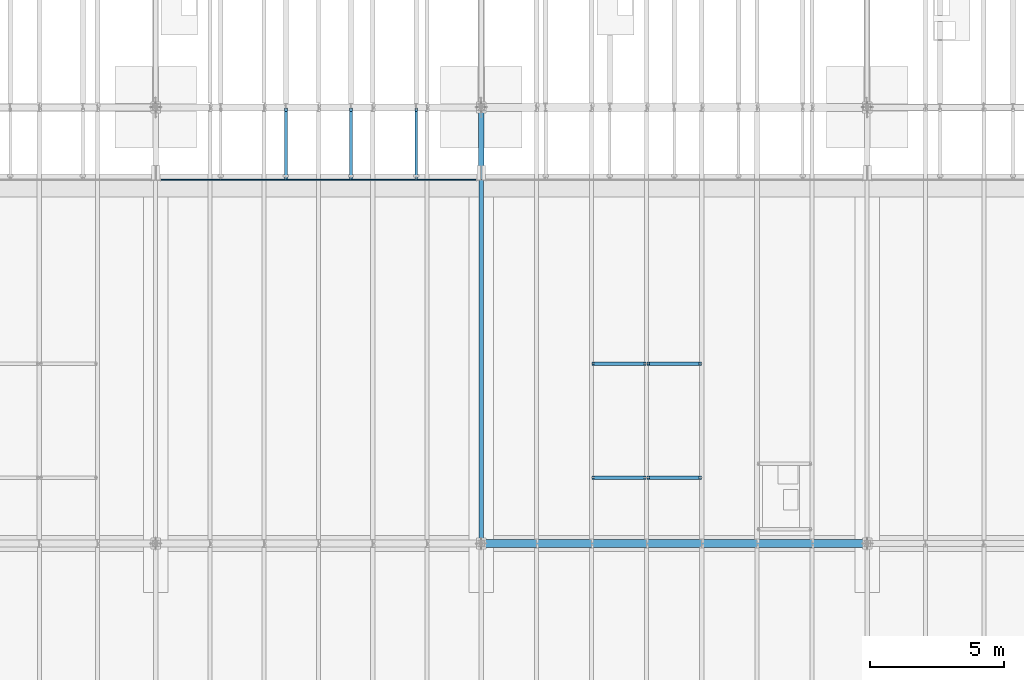
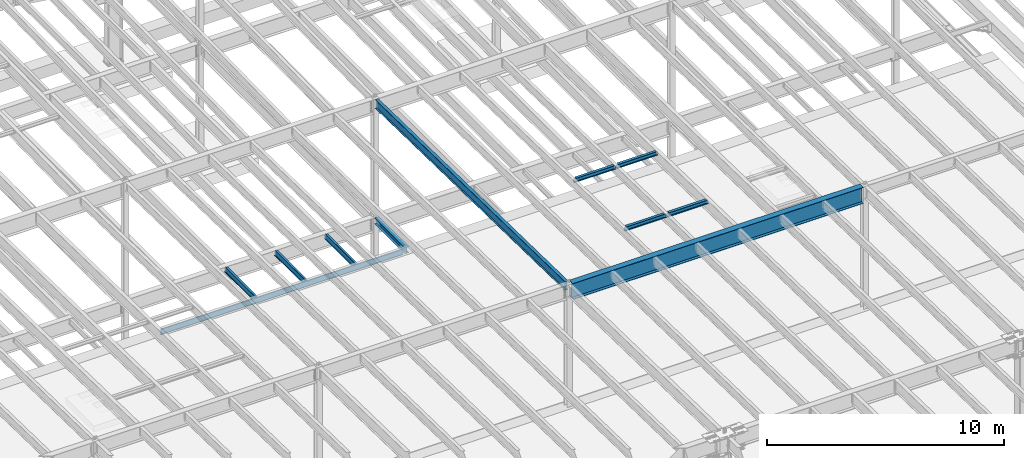
# One storey, part 1101 of 1763: 11 beams, 11 elements without a shape of their own.
"""IFC2X3 building model written with IfcOpenShell, lengths in millimetres."""

import ifcopenshell
import ifcopenshell.guid

model = None  # the IFC model being written
_history = None  # IfcOwnerHistory: only IFC2X3 demands one
_inside = {}  # id of a spatial element -> (the spatial element, [elements in it])
_under = {}  # id of a project, library or spatial element -> (it, [spatial elements below it])
_declared = {}  # id of a project -> (the project, [libraries it declares])
_typed = {}  # id of a type object -> (the type object, [elements of that type])
_made_of = {}  # id of a material, layer set ... -> (it, [elements and type objects made of it])


def new_model(schema):
    """Start an empty IFC model of exactly this schema.

    Asked for "IFC4X3", IfcOpenShell would pick the latest addendum, in which some entities
    have other attributes; the version numbers below select the first issue.
    IFC2X3 requires an IfcOwnerHistory on every rooted entity: one is made here for all.
    """
    global model, _history
    if schema == "IFC4X3":
        model = ifcopenshell.file(schema_version=(4, 3, 0, 0))
    else:
        model = ifcopenshell.file(schema=schema)
    _inside.clear()
    _under.clear()
    _declared.clear()
    _typed.clear()
    _made_of.clear()
    _history = None
    if model.schema == "IFC2X3":
        org = make("IfcOrganization", Name="unknown")
        user = make(
            "IfcPersonAndOrganization",
            ThePerson=make("IfcPerson", FamilyName="unknown"),
            TheOrganization=org,
        )
        app = make(
            "IfcApplication",
            ApplicationDeveloper=org,
            Version="unknown",
            ApplicationFullName="unknown",
            ApplicationIdentifier="unknown",
        )
        _history = make(
            "IfcOwnerHistory",
            OwningUser=user,
            OwningApplication=app,
            ChangeAction="ADDED",
            CreationDate=0,
        )
    return model


def make(cls, **values):
    """One entity of the class cls with the attributes given. An attribute that is None is left unset."""
    return model.create_entity(
        cls, **{name: value for name, value in values.items() if value is not None}
    )


def rooted(cls, **values):
    """An entity with a GlobalId (a new one), such as an element, a storey or a relation."""
    return make(cls, GlobalId=ifcopenshell.guid.new(), OwnerHistory=_history, **values)


def si_unit(unit_type, name, prefix=None):
    """IfcSIUnit, for example si_unit("LENGTHUNIT", "METRE", prefix="MILLI")."""
    return make("IfcSIUnit", UnitType=unit_type, Prefix=prefix, Name=name)


def assignment(units):
    """IfcUnitAssignment: the units of a project."""
    return None if units is None else make("IfcUnitAssignment", Units=units)


def point(xyz):
    """IfcCartesianPoint."""
    return None if xyz is None else make("IfcCartesianPoint", Coordinates=xyz)


def direction(xyz):
    """IfcDirection."""
    return None if xyz is None else make("IfcDirection", DirectionRatios=xyz)


def frame(location, z_axis=None, x_axis=None):
    """IfcAxis2Placement3D, a coordinate frame: its origin and axes. An axis left out is left unset."""
    return make(
        "IfcAxis2Placement3D",
        Location=point(location),
        Axis=direction(z_axis),
        RefDirection=direction(x_axis),
    )


def origin_with_axes():
    """The frame at (0, 0, 0) with the z axis (0, 0, 1) and the x axis (1, 0, 0) written out."""
    return frame((0.0, 0.0, 0.0), z_axis=(0.0, 0.0, 1.0), x_axis=(1.0, 0.0, 0.0))


def place(relative_to, where):
    """IfcLocalPlacement: puts the frame where relative to a parent placement (None: the world)."""
    return make(
        "IfcLocalPlacement", PlacementRelTo=relative_to, RelativePlacement=where
    )


def context(
    kind, dimensions, precision=None, world=None, true_north=None, identifier=None
):
    """IfcGeometricRepresentationContext, for example the 3D "Model" context."""
    return make(
        "IfcGeometricRepresentationContext",
        ContextIdentifier=identifier,
        ContextType=kind,
        CoordinateSpaceDimension=dimensions,
        Precision=precision,
        WorldCoordinateSystem=world,
        TrueNorth=true_north,
    )


def subcontext(parent, identifier, kind, view, scale=None):
    """IfcGeometricRepresentationSubContext, for example "Body" below "Model"."""
    return make(
        "IfcGeometricRepresentationSubContext",
        ContextIdentifier=identifier,
        ContextType=kind,
        ParentContext=parent,
        TargetScale=scale,
        TargetView=view,
    )


def project(units=None, contexts=None):
    """IfcProject with its units and contexts."""
    return rooted(
        "IfcProject",
        Name="project",
        RepresentationContexts=contexts,
        UnitsInContext=assignment(units),
    )


def spatial(cls, under=None, at=None, **own):
    """A site, building, storey or space (cls), placed at a placement, below another one or the project."""
    s = rooted(cls, ObjectPlacement=at, **own)
    if under is not None:
        _under.setdefault(under.id(), (under, []))[1].append(s)
    return s


def faces_of(points, faces, orient=None, outer=None):
    """IfcFace entities. A face is a list of loops; a loop is a list of indices into points, from 0.

    orient and outer hold one flag for each loop. By default every Orientation is true, the
    first loop of a face is its IfcFaceOuterBound and the others are IfcFaceBound.
    """
    made = []
    for i, loops in enumerate(faces):
        bounds = []
        for j, loop in enumerate(loops):
            is_outer = j == 0 if outer is None else outer[i][j]
            bounds.append(
                make(
                    "IfcFaceOuterBound" if is_outer else "IfcFaceBound",
                    Bound=make("IfcPolyLoop", Polygon=[points[k] for k in loop]),
                    Orientation=True if orient is None else orient[i][j],
                )
            )
        made.append(make("IfcFace", Bounds=bounds))
    return made


def faceted_brep(points, faces, orient=None, outer=None, voids=None):
    """IfcFacetedBrep: a solid bounded by flat faces; with voids (closed shells), ...WithVoids."""
    shared = [point(p) for p in points]
    hull = make("IfcClosedShell", CfsFaces=faces_of(shared, faces, orient, outer))
    if voids is None:
        return make("IfcFacetedBrep", Outer=hull)
    return make(
        "IfcFacetedBrepWithVoids",
        Outer=hull,
        Voids=[
            make(cls, CfsFaces=faces_of(shared, fs, o, b)) for cls, fs, o, b in voids
        ],
    )


def shape(context_of_items, identifier, shape_type, items):
    """IfcShapeRepresentation: the items that make up one representation, for example the "Body"."""
    return make(
        "IfcShapeRepresentation",
        ContextOfItems=context_of_items,
        RepresentationIdentifier=identifier,
        RepresentationType=shape_type,
        Items=items,
    )


def material(Name=None, Category=None):
    """IfcMaterial."""
    return make("IfcMaterial", Name=Name, Category=Category)


def made_of(thing, what):
    """Note that an element or type object is made of a material, layer set ...; save() writes the relation."""
    if what is not None:
        _made_of.setdefault(what.id(), (what, []))[1].append(thing)
    return thing


def type_object(cls, material=None, **own):
    """A type object (cls), such as IfcWallType, which elements share."""
    return made_of(rooted(cls, **own), material)


def element(
    cls,
    number,
    at=None,
    inside=None,
    cuts=None,
    type_object=None,
    material=None,
    context=None,
    identifier="Body",
    shape_type=None,
    held_by="IfcProductDefinitionShape",
    body=None,
    shapes=None,
    **own,
):
    """One element of the class cls, such as IfcWall. Its Tag is "e" and its number.

    at: its placement. inside: the storey or other place that contains it. cuts: it is an
    opening in that element (IfcRelVoidsElement). A single representation is given by context,
    identifier, shape_type and body (its items); several are given by shapes. held_by: the class
    of the entity that holds the representations. save() writes the other relations.
    """
    e = rooted(cls, Tag="e%d" % number, ObjectPlacement=at, **own)
    if body is not None:
        shapes = [shape(context, identifier, shape_type, body)]
    if shapes is not None:
        e.Representation = make(held_by, Representations=shapes)
    if inside is not None:
        _inside.setdefault(inside.id(), (inside, []))[1].append(e)
    if cuts is not None:
        rooted(
            "IfcRelVoidsElement", RelatingBuildingElement=cuts, RelatedOpeningElement=e
        )
    if type_object is not None:
        _typed.setdefault(type_object.id(), (type_object, []))[1].append(e)
    return made_of(e, material)


def aggregate(whole, parts):
    """IfcRelAggregates: a whole, such as a stair, and the parts it consists of."""
    return rooted("IfcRelAggregates", RelatingObject=whole, RelatedObjects=parts)


def save(model, path):
    """Write the relations noted so far, then the file.

    IfcRelAggregates (storeys below a building ...), IfcRelContainedInSpatialStructure (elements
    in a storey), IfcRelDefinesByType, IfcRelAssociatesMaterial and IfcRelDeclares: one each for
    every whole, place, type object, material and project.
    """
    for whole, parts in _under.values():
        aggregate(whole, parts)
    for where, things in _inside.values():
        rooted(
            "IfcRelContainedInSpatialStructure",
            RelatedElements=things,
            RelatingStructure=where,
        )
    for kind, things in _typed.values():
        rooted("IfcRelDefinesByType", RelatedObjects=things, RelatingType=kind)
    for what, things in _made_of.values():
        rooted("IfcRelAssociatesMaterial", RelatedObjects=things, RelatingMaterial=what)
    for by, libraries in _declared.values():
        rooted("IfcRelDeclares", RelatingContext=by, RelatedDefinitions=libraries)
    model.write(path)


model = new_model("IFC2X3")

# Units and contexts
model_context = context("Model", 3, precision=1e-05, world=origin_with_axes())
body_context = subcontext(model_context, "Body", "Model", "MODEL_VIEW")
ifc_project = project(units=[si_unit("LENGTHUNIT", "METRE", prefix="MILLI"), si_unit("AREAUNIT", "SQUARE_METRE"), si_unit("VOLUMEUNIT", "CUBIC_METRE"), si_unit("MASSUNIT", "GRAM", prefix="KILO"), si_unit("TIMEUNIT", "SECOND"), si_unit("PLANEANGLEUNIT", "RADIAN"), si_unit("SOLIDANGLEUNIT", "STERADIAN"), si_unit("THERMODYNAMICTEMPERATUREUNIT", "DEGREE_CELSIUS"), si_unit("LUMINOUSINTENSITYUNIT", "LUMEN")], contexts=[model_context])

# Site, building, storey
site_placement = place(None, origin_with_axes())
site = spatial("IfcSite", under=ifc_project, at=site_placement, CompositionType="ELEMENT")
building_placement = place(site_placement, origin_with_axes())
building = spatial("IfcBuilding", under=site, at=building_placement, Name="Undefined", CompositionType="ELEMENT")
storey_placement = place(building_placement, origin_with_axes())
storey = spatial("IfcBuildingStorey", under=building, at=storey_placement, Name="Undefined", CompositionType="ELEMENT", Elevation=0.0)

# Assembly, beam
assembly_1_placement = place(storey_placement, origin_with_axes())
assembly_1 = element("IfcElementAssembly", 1, at=assembly_1_placement, inside=storey, Name="BEAM", AssemblyPlace="NOTDEFINED", PredefinedType="RIGID_FRAME")
ifc_material = material(Name="STEEL/A992")
beam_type_1 = type_object("IfcBeamType", Name="W8X18", PredefinedType="NOTDEFINED")
beam_1_placement = place(assembly_1_placement, frame((-45273.1229879841, 20421.6000000266, 11387.8344547136), z_axis=(0.0, 0.0, 1.0), x_axis=(1.0, 0.0, 0.0)))
beam_1 = element("IfcBeam", 2, at=beam_1_placement, type_object=beam_type_1, material=ifc_material, Name="BEAM", ObjectType="W8X18", context=body_context, shape_type="Brep", body=[
    faceted_brep([(86.5187501907203, -3.17499999999927, 64.8275016886455), (86.5187501907203, 3.17499999999927, 64.8275016886455), (16.6687499999825, 3.17499999999927, 64.8275016886455), (16.6687499999825, -3.17499999999927, 64.8275016886455), (91.3788297087667, -3.17499999999927, 65.794231611233), (91.3788297087667, 3.17499999999927, 65.794231611233), (95.4990061769204, -3.17499999999927, 68.5472455117106), (95.4990061769204, 3.17499999999927, 68.5472455117106), (98.2520200773943, -3.17499999999927, 72.6674219798642), (98.2520200773943, 3.17499999999927, 72.6674219798642), (99.2187499999854, -3.17499999999927, 77.5275014979106), (99.2187499999854, 3.17499999999927, 77.5275014979106), (99.2187499999854, -66.6749999999993, 103.1875), (99.2187499999854, 66.6749999999993, 103.1875), (99.2187499999854, 66.6749999999993, 95.25), (99.2187499999854, 3.17499999999927, 95.25), (99.2187499999854, -3.17499999999927, 95.25), (99.2187499999854, -66.6749999999993, 95.25), (16.6687499999971, -3.17500000000291, -95.25), (16.6687499999971, -66.6750000000029, -95.25), (2047.98839285714, -66.6750000000029, -95.25), (2047.98839285714, -3.17500000000291, -95.25), (16.6687499999971, -66.6750000000029, -103.1875), (2047.98839285714, -66.6750000000029, -103.1875), (16.6687499999971, 66.6750000000029, -103.1875), (2047.98839285714, 66.6750000000029, -103.1875), (16.6687499999971, 66.6750000000029, -95.25), (2047.98839285714, 66.6750000000029, -95.25), (16.6687499999971, 3.17500000000291, -95.25), (2047.98839285714, 3.17500000000291, -95.25), (2047.98839285715, 3.17499999999927, 64.8275016807074), (2047.98839285715, -3.17499999999927, 64.8275016807074), (1978.13839266641, 3.17499999999927, 64.8275016807074), (1978.13839266641, -3.17499999999927, 64.8275016807074), (1977.37485297738, -3.17499999999927, 64.9793791678421), (1977.37485297738, 3.17499999999927, 64.9793791678421), (1973.27831314837, 3.17499999999927, 65.794231603295), (1973.27831314837, -3.17499999999927, 65.794231603295), (1972.48456314837, 3.17499999999927, 65.794231601054), (1972.48456314837, -3.17499999999927, 65.794231601054), (1968.36438668022, 3.17499999999927, 68.5472455015315), (1968.36438668022, -3.17499999999927, 68.5472455015315), (1965.61137277974, 3.17499999999927, 72.6674219696852), (1965.61137277974, -3.17499999999927, 72.6674219696852), (1964.64464285715, 3.17499999999927, 77.5275014877316), (1964.64464285715, -3.17499999999927, 77.5275014877316), (1964.64464285715, -66.6749999999993, 103.1875), (1964.64464285715, -66.6749999999993, 95.25), (1964.64464285715, -3.17499999999927, 95.25), (1964.64464285715, 3.17499999999927, 95.25), (1964.64464285715, 66.6749999999993, 95.25), (1964.64464285715, 66.6749999999993, 103.1875)], [[[0, 1, 2, 3]], [[4, 5, 1, 0]], [[6, 7, 5, 4]], [[8, 9, 7, 6]], [[10, 11, 9, 8]], [[12, 13, 14, 15, 11, 10, 16, 17]], [[18, 19, 20, 21]], [[19, 22, 23, 20]], [[22, 24, 25, 23]], [[24, 26, 27, 25]], [[26, 28, 29, 27]], [[21, 20, 23, 25, 27, 29, 30, 31]], [[31, 30, 32, 33]], [[34, 33, 32, 35, 36, 37]], [[37, 36, 38, 39]], [[39, 38, 40, 41]], [[41, 40, 42, 43]], [[43, 42, 44, 45]], [[46, 47, 48, 45, 44, 49, 50, 51]], [[47, 46, 12, 17]], [[48, 47, 17, 16]], [[8, 6, 4, 0, 3, 18, 21, 31, 33, 34, 37, 39, 41, 43, 45, 48, 16, 10]], [[28, 26, 24, 22, 19, 18, 3, 2]], [[49, 44, 42, 40, 38, 36, 35, 32, 30, 29, 28, 2, 1, 5, 7, 9, 11, 15]], [[50, 49, 15, 14]], [[51, 50, 14, 13]], [[46, 51, 13, 12]]]),
])
aggregate(assembly_1, [beam_1])

assembly_2_placement = place(storey_placement, origin_with_axes())
assembly_2 = element("IfcElementAssembly", 3, at=assembly_2_placement, inside=storey, Name="BEAM", AssemblyPlace="NOTDEFINED", PredefinedType="RIGID_FRAME")
beam_2_placement = place(assembly_2_placement, frame((-45273.1229879841, 16154.4000000266, 11477.0442138004), z_axis=(0.0, 0.0, 1.0), x_axis=(1.0, 0.0, 0.0)))
beam_2 = element("IfcBeam", 4, at=beam_2_placement, type_object=beam_type_1, material=ifc_material, Name="BEAM", ObjectType="W8X18", context=body_context, shape_type="Brep", body=[
    faceted_brep([(86.5187501907203, -3.17499999999927, 64.8275016886455), (86.5187501907203, 3.17499999999927, 64.8275016886455), (16.6687499999825, 3.17499999999927, 64.8275016886455), (16.6687499999825, -3.17499999999927, 64.8275016886455), (91.3788297087667, -3.17499999999927, 65.794231611233), (91.3788297087667, 3.17499999999927, 65.794231611233), (95.4990061769204, -3.17499999999927, 68.5472455117106), (95.4990061769204, 3.17499999999927, 68.5472455117106), (98.2520200773943, -3.17499999999927, 72.6674219798642), (98.2520200773943, 3.17499999999927, 72.6674219798642), (99.2187499999854, -3.17499999999927, 77.5275014979106), (99.2187499999854, 3.17499999999927, 77.5275014979106), (99.2187499999854, -66.6749999999993, 103.1875), (99.2187499999854, 66.6749999999993, 103.1875), (99.2187499999854, 66.6749999999993, 95.25), (99.2187499999854, 3.17499999999927, 95.25), (99.2187499999854, -3.17499999999927, 95.25), (99.2187499999854, -66.6749999999993, 95.25), (16.6687499999971, -3.17500000000291, -95.25), (16.6687499999971, -66.6750000000029, -95.25), (2047.98839285714, -66.6750000000029, -95.25), (2047.98839285714, -3.17500000000291, -95.25), (16.6687499999971, -66.6750000000029, -103.1875), (2047.98839285714, -66.6750000000029, -103.1875), (16.6687499999971, 66.6750000000029, -103.1875), (2047.98839285714, 66.6750000000029, -103.1875), (16.6687499999971, 66.6750000000029, -95.25), (2047.98839285714, 66.6750000000029, -95.25), (16.6687499999971, 3.17500000000291, -95.25), (2047.98839285714, 3.17500000000291, -95.25), (2047.98839285715, 3.17499999999927, 64.8275016807074), (2047.98839285715, -3.17499999999927, 64.8275016807074), (1978.13839266641, 3.17499999999927, 64.8275016807074), (1978.13839266641, -3.17499999999927, 64.8275016807074), (1973.27831314837, 3.17499999999927, 65.794231603295), (1973.27831314837, -3.17499999999927, 65.794231603295), (1969.15813668021, 3.17499999999927, 68.5472454961891), (1969.15813668021, -3.17499999999927, 68.5472454961891), (1966.40512277974, 3.17499999999927, 72.6674219643428), (1966.40512277974, -3.17499999999927, 72.6674219643428), (1965.43839285715, 3.17499999999927, 77.5275014823892), (1965.43839285715, -3.17499999999927, 77.5275014823892), (1965.43839285715, -66.6749999999993, 103.1875), (1965.43839285715, -66.6749999999993, 95.25), (1965.43839285715, -3.17499999999927, 95.25), (1965.43839285715, 3.17499999999927, 95.25), (1965.43839285715, 66.6749999999993, 95.25), (1965.43839285715, 66.6749999999993, 103.1875)], [[[0, 1, 2, 3]], [[4, 5, 1, 0]], [[6, 7, 5, 4]], [[8, 9, 7, 6]], [[10, 11, 9, 8]], [[12, 13, 14, 15, 11, 10, 16, 17]], [[18, 19, 20, 21]], [[19, 22, 23, 20]], [[22, 24, 25, 23]], [[24, 26, 27, 25]], [[26, 28, 29, 27]], [[21, 20, 23, 25, 27, 29, 30, 31]], [[31, 30, 32, 33]], [[33, 32, 34, 35]], [[35, 34, 36, 37]], [[37, 36, 38, 39]], [[39, 38, 40, 41]], [[42, 43, 44, 41, 40, 45, 46, 47]], [[43, 42, 12, 17]], [[44, 43, 17, 16]], [[8, 6, 4, 0, 3, 18, 21, 31, 33, 35, 37, 39, 41, 44, 16, 10]], [[28, 26, 24, 22, 19, 18, 3, 2]], [[45, 40, 38, 36, 34, 32, 30, 29, 28, 2, 1, 5, 7, 9, 11, 15]], [[46, 45, 15, 14]], [[47, 46, 14, 13]], [[42, 47, 13, 12]]]),
])
aggregate(assembly_2, [beam_2])

assembly_3_placement = place(storey_placement, origin_with_axes())
assembly_3 = element("IfcElementAssembly", 5, at=assembly_3_placement, inside=storey, Name="BEAM", AssemblyPlace="NOTDEFINED", PredefinedType="RIGID_FRAME")
beam_3_placement = place(assembly_3_placement, frame((-43209.3125117936, 20421.6000000266, 11387.8344547136), z_axis=(0.0, 0.0, 1.0), x_axis=(1.0, 0.0, 0.0)))
beam_3 = element("IfcBeam", 6, at=beam_3_placement, type_object=beam_type_1, material=ifc_material, Name="BEAM", ObjectType="W8X18", context=body_context, shape_type="Brep", body=[
    faceted_brep([(1969.21105334689, -3.17499999999927, 68.5472455037398), (1969.21105334689, 3.17499999999927, 68.5472455037398), (1968.35109562836, 3.17499999999927, 69.8342631809446), (1968.35109562836, -3.17499999999927, 69.8342631809446), (1973.33122981504, -3.17499999999927, 65.7942316032622), (1973.33122981504, 3.17499999999927, 65.7942316032622), (1978.19130933309, -3.17499999999927, 64.8275016806747), (1978.19130933309, 3.17499999999927, 64.8275016806747), (2048.04130952383, -3.17499999999927, 64.8275016806747), (2048.04130952383, 3.17499999999927, 64.8275016806747), (1967.62355639863, -3.17499999999927, 70.3203893524969), (1967.62355639863, 3.17499999999927, 70.3203893524969), (1964.87054249815, 3.17499999999927, 74.4405658206506), (1964.87054249815, -3.17499999999927, 74.4405658206506), (1963.90381257556, 3.17499999999927, 79.300645338697), (1963.90381257556, -3.17499999999927, 79.300645338697), (1963.90381257556, -66.6749999999993, 103.1875), (1963.90381257556, -66.6749999999993, 95.25), (1963.90381257556, -3.17499999999927, 95.25), (1963.90381257556, 3.17499999999927, 95.25), (1963.90381257556, 66.6749999999993, 95.25), (1963.90381257556, 66.6749999999993, 103.1875), (100.065416666679, 3.17499999999927, 95.25), (100.065416666679, 66.6749999999993, 95.25), (100.065416666679, 66.6749999999993, 103.1875), (100.065416666679, -66.6749999999993, 103.1875), (100.065416666679, -66.6749999999993, 95.25), (100.065416666679, -3.17499999999927, 95.25), (100.065416666679, 3.17499999999927, 77.5275014979125), (100.065416666679, -3.17499999999927, 77.5275014979125), (99.0986867440879, 3.17499999999927, 72.667421979866), (99.0986867440879, -3.17499999999927, 72.667421979866), (96.345672843614, 3.17499999999927, 68.5472455117124), (96.345672843614, -3.17499999999927, 68.5472455117124), (92.2254963754604, 3.17499999999927, 65.7942316112349), (92.2254963754604, -3.17499999999927, 65.7942316112349), (87.3654168574139, 3.17499999999927, 64.8275016886473), (87.3654168574139, -3.17499999999927, 64.8275016886473), (17.5154166666762, 3.17499999999927, 64.8275016886473), (17.5154166666762, -3.17499999999927, 64.8275016886473), (17.5154166666762, 3.17499999999927, -95.25), (17.5154166666762, 66.6749999999993, -95.25), (17.5154166666762, 66.6749999999993, -103.1875), (17.5154166666762, -66.6749999999993, -103.1875), (17.5154166666762, -66.6749999999993, -95.25), (17.5154166666762, -3.17499999999927, -95.25), (2048.04130952383, 3.17499999999927, -95.25), (2048.04130952383, 66.6749999999993, -95.25), (2048.04130952383, 66.6749999999993, -103.1875), (2048.04130952383, -66.6749999999993, -103.1875), (2048.04130952383, -66.6749999999993, -95.25), (2048.04130952383, -3.17499999999927, -95.25)], [[[0, 1, 2, 3]], [[4, 5, 1, 0]], [[6, 7, 5, 4]], [[8, 9, 7, 6]], [[10, 11, 12, 13]], [[13, 12, 14, 15]], [[16, 17, 18, 15, 14, 19, 20, 21]], [[20, 19, 22, 23]], [[21, 20, 23, 24]], [[16, 21, 24, 25]], [[17, 16, 25, 26]], [[18, 17, 26, 27]], [[25, 24, 23, 22, 28, 29, 27, 26]], [[29, 28, 30, 31]], [[31, 30, 32, 33]], [[33, 32, 34, 35]], [[35, 34, 36, 37]], [[37, 36, 38, 39]], [[40, 41, 42, 43, 44, 45, 39, 38]], [[41, 40, 46, 47]], [[42, 41, 47, 48]], [[43, 42, 48, 49]], [[44, 43, 49, 50]], [[45, 44, 50, 51]], [[4, 0, 3, 10, 13, 15, 18, 27, 29, 31, 33, 35, 37, 39, 45, 51, 8, 6]], [[11, 10, 3, 2]], [[46, 40, 38, 36, 34, 32, 30, 28, 22, 19, 14, 12, 11, 2, 1, 5, 7, 9]], [[51, 50, 49, 48, 47, 46, 9, 8]]]),
])
aggregate(assembly_3, [beam_3])

assembly_4_placement = place(storey_placement, origin_with_axes())
assembly_4 = element("IfcElementAssembly", 7, at=assembly_4_placement, inside=storey, Name="BEAM", AssemblyPlace="NOTDEFINED", PredefinedType="RIGID_FRAME")
beam_4_placement = place(assembly_4_placement, frame((-43209.3125117936, 16154.4000000266, 11477.0442138004), z_axis=(0.0, 0.0, 1.0), x_axis=(1.0, 0.0, 0.0)))
beam_4 = element("IfcBeam", 8, at=beam_4_placement, type_object=beam_type_1, material=ifc_material, Name="BEAM", ObjectType="W8X18", context=body_context, shape_type="Brep", body=[
    faceted_brep([(87.3654168574139, -3.17499999999927, 64.8275016886473), (87.3654168574139, 3.17499999999927, 64.8275016886473), (17.5154166666762, 3.17499999999927, 64.8275016886473), (17.5154166666762, -3.17499999999927, 64.8275016886473), (92.2254963754604, -3.17499999999927, 65.7942316112349), (92.2254963754604, 3.17499999999927, 65.7942316112349), (96.345672843614, -3.17499999999927, 68.5472455117124), (96.345672843614, 3.17499999999927, 68.5472455117124), (99.0986867440879, -3.17499999999927, 72.667421979866), (99.0986867440879, 3.17499999999927, 72.667421979866), (100.065416666679, -3.17499999999927, 77.5275014979125), (100.065416666679, 3.17499999999927, 77.5275014979125), (100.065416666679, -66.6749999999993, 103.1875), (100.065416666679, 66.6749999999993, 103.1875), (100.065416666679, 66.6749999999993, 95.25), (100.065416666679, 3.17499999999927, 95.25), (100.065416666679, -3.17499999999927, 95.25), (100.065416666679, -66.6749999999993, 95.25), (17.5154166666762, -3.17499999999927, -95.25), (17.5154166666762, -66.6749999999993, -95.25), (2048.04130952383, -66.6749999999993, -95.25), (2048.04130952383, -3.17499999999927, -95.25), (17.5154166666762, -66.6749999999993, -103.1875), (2048.04130952383, -66.6749999999993, -103.1875), (17.5154166666762, 66.6749999999993, -103.1875), (2048.04130952383, 66.6749999999993, -103.1875), (17.5154166666762, 66.6749999999993, -95.25), (2048.04130952383, 66.6749999999993, -95.25), (17.5154166666762, 3.17499999999927, -95.25), (2048.04130952383, 3.17499999999927, -95.25), (2048.04130952383, 3.17499999999927, 64.8275016806747), (2048.04130952383, -3.17499999999927, 64.8275016806747), (1978.19130933309, 3.17499999999927, 64.8275016806747), (1978.19130933309, -3.17499999999927, 64.8275016806747), (1973.33122981504, 3.17499999999927, 65.7942316032622), (1973.33122981504, -3.17499999999927, 65.7942316032622), (1969.21105334689, 3.17499999999927, 68.5472455037398), (1969.21105334689, -3.17499999999927, 68.5472455037398), (1968.35109562836, 3.17499999999927, 69.8342631809446), (1968.35109562836, -3.17499999999927, 69.8342631809446), (1967.62355639863, 3.17499999999927, 70.3203893524969), (1967.62355639863, -3.17499999999927, 70.3203893524969), (1964.87054249815, 3.17499999999927, 74.4405658206506), (1964.87054249815, -3.17499999999927, 74.4405658206506), (1963.90381257556, 3.17499999999927, 79.300645338697), (1963.90381257556, -3.17499999999927, 79.300645338697), (1963.90381257556, -66.6749999999993, 103.1875), (1963.90381257556, -66.6749999999993, 95.25), (1963.90381257556, -3.17499999999927, 95.25), (1963.90381257556, 3.17499999999927, 95.25), (1963.90381257556, 66.6749999999993, 95.25), (1963.90381257556, 66.6749999999993, 103.1875)], [[[0, 1, 2, 3]], [[4, 5, 1, 0]], [[6, 7, 5, 4]], [[8, 9, 7, 6]], [[10, 11, 9, 8]], [[12, 13, 14, 15, 11, 10, 16, 17]], [[18, 19, 20, 21]], [[19, 22, 23, 20]], [[22, 24, 25, 23]], [[24, 26, 27, 25]], [[26, 28, 29, 27]], [[21, 20, 23, 25, 27, 29, 30, 31]], [[31, 30, 32, 33]], [[33, 32, 34, 35]], [[35, 34, 36, 37]], [[37, 36, 38, 39]], [[40, 41, 39, 38]], [[41, 40, 42, 43]], [[43, 42, 44, 45]], [[46, 47, 48, 45, 44, 49, 50, 51]], [[47, 46, 12, 17]], [[48, 47, 17, 16]], [[35, 37, 39, 41, 43, 45, 48, 16, 10, 8, 6, 4, 0, 3, 18, 21, 31, 33]], [[28, 26, 24, 22, 19, 18, 3, 2]], [[29, 28, 2, 1, 5, 7, 9, 11, 15, 49, 44, 42, 40, 38, 36, 34, 32, 30]], [[50, 49, 15, 14]], [[51, 50, 14, 13]], [[46, 51, 13, 12]]]),
])
aggregate(assembly_4, [beam_4])

assembly_5_placement = place(storey_placement, origin_with_axes())
assembly_5 = element("IfcElementAssembly", 9, at=assembly_5_placement, inside=storey, Name="BEAM", AssemblyPlace="NOTDEFINED", PredefinedType="RIGID_FRAME")
beam_type_2 = type_object("IfcBeamType", Name="W12X16", PredefinedType="NOTDEFINED")
beam_5_placement = place(assembly_5_placement, frame((-51840.8372736984, 27279.6, 5041.9), z_axis=(0.0, 0.0, 1.0), x_axis=(0.0, 1.0, 0.0)))
beam_5 = element("IfcBeam", 10, at=beam_5_placement, type_object=beam_type_2, material=ifc_material, Name="BEAM", ObjectType="W12X16", context=body_context, shape_type="Brep", body=[
    faceted_brep([(63.5000000000036, -3.17499999999927, -146.05), (63.5000000000036, -50.7999999999993, -146.05), (2724.15000000001, -50.7999999999993, -146.05), (2724.15000000001, -3.17499999999927, -146.05), (63.5000000000036, -50.7999999999993, -152.4), (2724.15000000001, -50.7999999999993, -152.4), (63.5000000000036, 50.7999999999993, -152.4), (2724.15000000001, 50.7999999999993, -152.4), (63.5000000000036, 50.7999999999993, -146.05), (63.5000000000036, 3.17499999999927, -146.05), (2724.15000000001, 3.17499999999927, -146.05), (2724.15000000001, 50.7999999999993, -146.05), (2724.15000000001, 3.17499999999927, 120.390001678466), (2724.15000000001, -3.17499999999927, 120.390001678466), (63.5000000000036, -3.17499999999927, 146.05), (63.5000000000036, -50.7999999999993, 146.05), (63.5000000000036, -50.7999999999993, 152.4), (63.5000000000036, 50.7999999999993, 152.4), (63.5000000000036, 50.7999999999993, 146.05), (63.5000000000036, 3.17499999999927, 146.05), (2597.15000000001, 50.7999999999993, 146.05), (2597.15000000001, 3.17499999999927, 146.05), (2597.15000000001, 3.17499999999927, 133.090001487731), (2598.11672992259, 3.17499999999927, 128.229921969685), (2600.86974382307, 3.17499999999927, 124.109745501532), (2604.98992029122, 3.17499999999927, 121.356731601053), (2609.84999980927, 3.17499999999927, 120.390001678466), (2598.11672992259, -3.17499999999927, 128.229921969685), (2597.15000000001, -3.17499999999927, 133.090001487731), (2600.86974382307, -3.17499999999927, 124.109745501532), (2604.98992029122, -3.17499999999927, 121.356731601053), (2609.84999980927, -3.17499999999927, 120.390001678466), (2597.15000000001, -3.17499999999927, 146.05), (2597.15000000001, -50.7999999999993, 146.05), (2597.15000000001, -50.7999999999993, 152.4), (2597.15000000001, 50.7999999999993, 152.4)], [[[0, 1, 2, 3]], [[1, 4, 5, 2]], [[4, 6, 7, 5]], [[8, 9, 10, 11]], [[3, 2, 5, 7, 11, 10, 12, 13]], [[6, 8, 11, 7]], [[4, 1, 0, 14, 15, 16, 17, 18, 19, 9, 8, 6]], [[19, 18, 20, 21]], [[10, 9, 19, 21, 22, 23, 24, 25, 26, 12]], [[27, 23, 22, 28]], [[29, 24, 23, 27]], [[30, 25, 24, 29]], [[31, 26, 25, 30]], [[13, 12, 26, 31]], [[30, 29, 27, 28, 32, 14, 0, 3, 13, 31]], [[15, 14, 32, 33]], [[16, 15, 33, 34]], [[17, 16, 34, 35]], [[18, 17, 35, 20]], [[34, 33, 32, 28, 22, 21, 20, 35]]]),
])
aggregate(assembly_5, [beam_5])

assembly_6_placement = place(storey_placement, origin_with_axes())
assembly_6 = element("IfcElementAssembly", 11, at=assembly_6_placement, inside=storey, Name="BEAM", AssemblyPlace="NOTDEFINED", PredefinedType="RIGID_FRAME")
beam_6_placement = place(assembly_6_placement, frame((-54279.2372736983, 27279.6, 5041.9), z_axis=(0.0, 0.0, 1.0), x_axis=(0.0, 1.0, 0.0)))
beam_6 = element("IfcBeam", 12, at=beam_6_placement, type_object=beam_type_2, material=ifc_material, Name="BEAM", ObjectType="W12X16", context=body_context, shape_type="Brep", body=[
    faceted_brep([(63.5000000000036, -3.17499999999927, -146.05), (63.5000000000036, -50.7999999999993, -146.05), (2724.15000000001, -50.7999999999993, -146.05), (2724.15000000001, -3.17499999999927, -146.05), (63.5000000000036, -50.7999999999993, -152.4), (2724.15000000001, -50.7999999999993, -152.4), (63.5000000000036, 50.7999999999993, -152.4), (2724.15000000001, 50.7999999999993, -152.4), (63.5000000000036, 50.7999999999993, -146.05), (63.5000000000036, 3.17499999999927, -146.05), (2724.15000000001, 3.17499999999927, -146.05), (2724.15000000001, 50.7999999999993, -146.05), (2724.15000000001, 3.17499999999927, 120.390001678466), (2724.15000000001, -3.17499999999927, 120.390001678466), (63.5000000000036, -3.17499999999927, 146.05), (63.5000000000036, -50.7999999999993, 146.05), (63.5000000000036, -50.7999999999993, 152.4), (63.5000000000036, 50.7999999999993, 152.4), (63.5000000000036, 50.7999999999993, 146.05), (63.5000000000036, 3.17499999999927, 146.05), (2597.15000000001, 50.7999999999993, 146.05), (2597.15000000001, 3.17499999999927, 146.05), (2597.15000000001, 3.17499999999927, 133.090001487731), (2598.11672992259, 3.17499999999927, 128.229921969685), (2600.86974382307, 3.17499999999927, 124.109745501532), (2604.98992029122, 3.17499999999927, 121.356731601053), (2609.84999980927, 3.17499999999927, 120.390001678466), (2598.11672992259, -3.17499999999927, 128.229921969685), (2597.15000000001, -3.17499999999927, 133.090001487731), (2600.86974382307, -3.17499999999927, 124.109745501532), (2604.98992029122, -3.17499999999927, 121.356731601053), (2609.84999980927, -3.17499999999927, 120.390001678466), (2597.15000000001, -3.17499999999927, 146.05), (2597.15000000001, -50.7999999999993, 146.05), (2597.15000000001, -50.7999999999993, 152.4), (2597.15000000001, 50.7999999999993, 152.4)], [[[0, 1, 2, 3]], [[1, 4, 5, 2]], [[4, 6, 7, 5]], [[8, 9, 10, 11]], [[3, 2, 5, 7, 11, 10, 12, 13]], [[6, 8, 11, 7]], [[4, 1, 0, 14, 15, 16, 17, 18, 19, 9, 8, 6]], [[19, 18, 20, 21]], [[10, 9, 19, 21, 22, 23, 24, 25, 26, 12]], [[27, 23, 22, 28]], [[29, 24, 23, 27]], [[30, 25, 24, 29]], [[31, 26, 25, 30]], [[13, 12, 26, 31]], [[30, 29, 27, 28, 32, 14, 0, 3, 13, 31]], [[15, 14, 32, 33]], [[16, 15, 33, 34]], [[17, 16, 34, 35]], [[18, 17, 35, 20]], [[34, 33, 32, 28, 22, 21, 20, 35]]]),
])
aggregate(assembly_6, [beam_6])

assembly_7_placement = place(storey_placement, origin_with_axes())
assembly_7 = element("IfcElementAssembly", 13, at=assembly_7_placement, inside=storey, Name="BEAM", AssemblyPlace="NOTDEFINED", PredefinedType="RIGID_FRAME")
beam_7_placement = place(assembly_7_placement, frame((-56717.6372736983, 27279.6, 5041.9), z_axis=(0.0, 0.0, 1.0), x_axis=(0.0, 1.0, 0.0)))
beam_7 = element("IfcBeam", 14, at=beam_7_placement, type_object=beam_type_2, material=ifc_material, Name="BEAM", ObjectType="W12X16", context=body_context, shape_type="Brep", body=[
    faceted_brep([(63.5000000000036, -3.17499999999927, -146.05), (63.5000000000036, -50.7999999999993, -146.05), (2724.15000000001, -50.7999999999993, -146.05), (2724.15000000001, -3.17499999999927, -146.05), (63.5000000000036, -50.7999999999993, -152.4), (2724.15000000001, -50.7999999999993, -152.4), (63.5000000000036, 50.7999999999993, -152.4), (2724.15000000001, 50.7999999999993, -152.4), (63.5000000000036, 50.7999999999993, -146.05), (63.5000000000036, 3.17499999999927, -146.05), (2724.15000000001, 3.17499999999927, -146.05), (2724.15000000001, 50.7999999999993, -146.05), (2724.15000000001, 3.17499999999927, 120.390001678466), (2724.15000000001, -3.17499999999927, 120.390001678466), (63.5000000000036, -3.17499999999927, 146.05), (63.5000000000036, -50.7999999999993, 146.05), (63.5000000000036, -50.7999999999993, 152.4), (63.5000000000036, 50.7999999999993, 152.4), (63.5000000000036, 50.7999999999993, 146.05), (63.5000000000036, 3.17499999999927, 146.05), (2597.15000000001, 50.7999999999993, 146.05), (2597.15000000001, 3.17499999999927, 146.05), (2597.15000000001, 3.17499999999927, 133.090001487731), (2598.11672992259, 3.17499999999927, 128.229921969685), (2600.86974382307, 3.17499999999927, 124.109745501532), (2604.98992029122, 3.17499999999927, 121.356731601053), (2609.84999980927, 3.17499999999927, 120.390001678466), (2598.11672992259, -3.17499999999927, 128.229921969685), (2597.15000000001, -3.17499999999927, 133.090001487731), (2600.86974382307, -3.17499999999927, 124.109745501532), (2604.98992029122, -3.17499999999927, 121.356731601053), (2609.84999980927, -3.17499999999927, 120.390001678466), (2597.15000000001, -3.17499999999927, 146.05), (2597.15000000001, -50.7999999999993, 146.05), (2597.15000000001, -50.7999999999993, 152.4), (2597.15000000001, 50.7999999999993, 152.4)], [[[0, 1, 2, 3]], [[1, 4, 5, 2]], [[4, 6, 7, 5]], [[8, 9, 10, 11]], [[3, 2, 5, 7, 11, 10, 12, 13]], [[6, 8, 11, 7]], [[4, 1, 0, 14, 15, 16, 17, 18, 19, 9, 8, 6]], [[19, 18, 20, 21]], [[10, 9, 19, 21, 22, 23, 24, 25, 26, 12]], [[27, 23, 22, 28]], [[29, 24, 23, 27]], [[30, 25, 24, 29]], [[31, 26, 25, 30]], [[13, 12, 26, 31]], [[30, 29, 27, 28, 32, 14, 0, 3, 13, 31]], [[15, 14, 32, 33]], [[16, 15, 33, 34]], [[17, 16, 34, 35]], [[18, 17, 35, 20]], [[34, 33, 32, 28, 22, 21, 20, 35]]]),
])
aggregate(assembly_7, [beam_7])

assembly_8_placement = place(storey_placement, origin_with_axes())
assembly_8 = element("IfcElementAssembly", 15, at=assembly_8_placement, inside=storey, Name="BEAM", AssemblyPlace="NOTDEFINED", PredefinedType="RIGID_FRAME")
beam_type_3 = type_object("IfcBeamType", Name="W18X40", PredefinedType="NOTDEFINED")
beam_8_placement = place(assembly_8_placement, frame((-49402.4372736983, 13685.8551306911, 11404.7768219844), z_axis=(0.0, 0.0209013539966291, 0.999781542838788), x_axis=(0.0, 0.999781542776098, -0.0209013569953182)))
beam_8 = element("IfcBeam", 16, at=beam_8_placement, type_object=beam_type_3, material=ifc_material, Name="BEAM", ObjectType="W18X40", context=body_context, shape_type="Brep", body=[
    faceted_brep([(149.222337311263, -76.1999999999971, -227.012499999879), (149.222337311263, 76.1999999999971, -227.012499999879), (16200.7664130645, 76.1999999999971, -227.012499990429), (16200.7664130645, -76.1999999999971, -227.012499990429), (148.956832075886, -76.1999999999971, -214.31249999988), (148.956832075886, -3.96875, -214.31249999988), (139.996051629378, -3.96875, 214.31249999976), (139.996051629378, -76.1999999999971, 214.31249999976), (139.730529250521, -76.1999999999971, 227.012499999752), (139.730529250521, 76.1999999999971, 227.012499999752), (139.996051629378, 76.1999999999971, 214.31249999976), (139.996051629378, 3.96875, 214.31249999976), (148.956832075886, 3.96875, -214.31249999988), (148.956832075886, 76.1999999999971, -214.31249999988), (16200.5009078292, -76.1999999999971, -214.31249999043), (16200.5009078292, -3.96875, -214.31249999043), (16191.5401061352, -3.96875, 214.312500009502), (16191.5401061352, -76.1999999999971, 214.312500009502), (16191.2746008998, -76.1999999999971, 227.012500009499), (16191.2746008998, 76.1999999999971, 227.012500009499), (16191.5401061352, 76.1999999999971, 214.312500009502), (16191.5401061352, 3.96875, 214.312500009502), (16200.5009078292, 3.96875, -214.31249999043), (16200.5009078292, 76.1999999999971, -214.31249999043)], [[[0, 1, 2, 3]], [[0, 4, 5, 6, 7, 8, 9, 10, 11, 12, 13, 1]], [[5, 4, 14, 15]], [[6, 5, 15, 16]], [[7, 6, 16, 17]], [[8, 7, 17, 18]], [[9, 8, 18, 19]], [[10, 9, 19, 20]], [[11, 10, 20, 21]], [[12, 11, 21, 22]], [[13, 12, 22, 23]], [[1, 13, 23, 2]], [[22, 21, 20, 19, 18, 17, 16, 15, 14, 3, 2, 23]], [[4, 0, 3, 14]]]),
])
aggregate(assembly_8, [beam_8])

assembly_9_placement = place(storey_placement, origin_with_axes())
assembly_9 = element("IfcElementAssembly", 17, at=assembly_9_placement, inside=storey, Name="BEAM", AssemblyPlace="NOTDEFINED", PredefinedType="RIGID_FRAME")
beam_type_4 = type_object("IfcBeamType", Name="MC12X10.6", PredefinedType="NOTDEFINED")
beam_9_placement = place(assembly_9_placement, frame((-61411.8747736984, 27311.35, 5041.9), z_axis=(0.0, 0.0, 1.0), x_axis=(1.0, 0.0, 0.0)))
beam_9 = element("IfcBeam", 18, at=beam_9_placement, type_object=beam_type_4, material=ifc_material, Name="BEAM", ObjectType="MC12X10.6", context=body_context, shape_type="Brep", body=[
    faceted_brep([(0.0, 19.0499999999993, -152.4), (0.0, 19.0499999999993, 152.4), (11826.875, 19.0499999999993, 152.4), (11826.875, 19.0499999999993, -152.4), (0.0, -19.0499999999993, 152.4), (11826.875, -19.0499999999993, 152.4), (0.0, -19.0499999999993, 144.841595), (11826.875, -19.0499999999993, 144.841595), (0.0, 14.2874999999985, 144.17817875), (11826.875, 14.2874999999985, 144.17817875), (0.0, 14.2874999999985, -144.17817875), (11826.875, 14.2874999999985, -144.17817875), (0.0, -19.0499999999993, -144.841595), (11826.875, -19.0499999999993, -144.841595), (0.0, -19.0499999999993, -152.4), (11826.875, -19.0499999999993, -152.4)], [[[0, 1, 2, 3]], [[1, 4, 5, 2]], [[4, 6, 7, 5]], [[6, 8, 9, 7]], [[8, 10, 11, 9]], [[10, 12, 13, 11]], [[12, 14, 15, 13]], [[14, 0, 3, 15]], [[5, 7, 9, 11, 13, 15, 3, 2]], [[14, 12, 10, 8, 6, 4, 1, 0]]]),
])
aggregate(assembly_9, [beam_9])

assembly_10_placement = place(storey_placement, origin_with_axes())
assembly_10 = element("IfcElementAssembly", 19, at=assembly_10_placement, inside=storey, Name="BEAM", AssemblyPlace="NOTDEFINED", PredefinedType="RIGID_FRAME")
beam_type_5 = type_object("IfcBeamType", Name="W33X118", PredefinedType="NOTDEFINED")
beam_10_placement = place(assembly_10_placement, frame((-49402.4372736983, 13690.599999996, 11214.2272294638), z_axis=(0.0, 0.0, 1.0), x_axis=(1.0, 0.0, 0.0)))
beam_10 = element("IfcBeam", 20, at=beam_10_placement, type_object=beam_type_5, material=ifc_material, Name="BEAM", ObjectType="W33X118", context=body_context, shape_type="Brep", body=[
    faceted_brep([(139.699999999997, 146.049999999999, -417.512500000001), (139.699999999997, 146.049999999999, -398.4625), (14312.9, 146.049999999999, -398.4625), (14312.9, 146.049999999999, -417.512500000001), (139.699999999997, 7.14374999999927, -398.4625), (14312.9, 7.14374999999927, -398.4625), (139.699999999997, 7.14374999999927, 398.4625), (14312.9, 7.14374999999927, 398.4625), (139.699999999997, 146.049999999999, 398.4625), (14312.9, 146.049999999999, 398.4625), (139.699999999997, 146.049999999999, 417.512500000001), (14312.9, 146.049999999999, 417.512500000001), (139.699999999997, -146.049999999999, 417.512500000001), (14312.9, -146.049999999999, 417.512500000001), (139.699999999997, -146.049999999999, 398.4625), (14312.9, -146.049999999999, 398.4625), (139.699999999997, -7.14374999999927, 398.4625), (14312.9, -7.14374999999927, 398.4625), (139.699999999997, -7.14374999999927, -398.4625), (14312.9, -7.14374999999927, -398.4625), (139.699999999997, -146.049999999999, -398.4625), (14312.9, -146.049999999999, -398.4625), (139.699999999997, -146.049999999999, -417.512500000001), (14312.9, -146.049999999999, -417.512500000001)], [[[0, 1, 2, 3]], [[1, 4, 5, 2]], [[4, 6, 7, 5]], [[6, 8, 9, 7]], [[8, 10, 11, 9]], [[10, 12, 13, 11]], [[12, 14, 15, 13]], [[14, 16, 17, 15]], [[16, 18, 19, 17]], [[18, 20, 21, 19]], [[20, 22, 23, 21]], [[22, 0, 3, 23]], [[5, 7, 9, 11, 13, 15, 17, 19, 21, 23, 3, 2]], [[22, 20, 18, 16, 14, 12, 10, 8, 6, 4, 1, 0]]]),
])
aggregate(assembly_10, [beam_10])

assembly_11_placement = place(storey_placement, origin_with_axes())
assembly_11 = element("IfcElementAssembly", 21, at=assembly_11_placement, inside=storey, Name="BEAM", AssemblyPlace="NOTDEFINED", PredefinedType="RIGID_FRAME")
beam_type_6 = type_object("IfcBeamType", Name="W12X50", PredefinedType="NOTDEFINED")
beam_11_placement = place(assembly_11_placement, frame((-49402.4372736983, 27279.6, 5038.725), z_axis=(0.0, 0.0, 1.0), x_axis=(0.0, 1.0, 0.0)))
beam_11 = element("IfcBeam", 22, at=beam_11_placement, type_object=beam_type_6, material=ifc_material, Name="BEAM", ObjectType="W12X50", context=body_context, shape_type="Brep", body=[
    faceted_brep([(50.7999999999993, -103.1875, -139.7), (50.7999999999993, -103.1875, -155.575), (2598.7375, -103.1875, -155.575), (2598.7375, -103.1875, -139.7), (50.7999999999993, -4.76250000000073, -139.7), (2598.7375, -4.76249999999709, -139.7), (50.7999999999993, -4.76250000000073, 139.7), (2598.7375, -4.76249999999709, 139.7), (50.7999999999993, -103.1875, 139.7), (2598.7375, -103.1875, 139.7), (50.7999999999993, -103.1875, 155.575), (2598.7375, -103.1875, 155.575), (50.7999999999993, 103.1875, 155.575), (2598.7375, 103.1875, 155.575), (50.7999999999993, 103.1875, 139.7), (2598.7375, 103.1875, 139.7), (50.7999999999993, 4.76250000000073, 139.7), (2598.7375, 4.76249999999709, 139.7), (50.7999999999993, 4.76250000000073, -139.7), (2598.7375, 4.76249999999709, -139.7), (50.7999999999993, 103.1875, -139.7), (2598.7375, 103.1875, -139.7), (50.7999999999993, 103.1875, -155.575), (2598.7375, 103.1875, -155.575)], [[[0, 1, 2, 3]], [[4, 0, 3, 5]], [[6, 4, 5, 7]], [[8, 6, 7, 9]], [[10, 8, 9, 11]], [[12, 10, 11, 13]], [[14, 12, 13, 15]], [[16, 14, 15, 17]], [[18, 16, 17, 19]], [[20, 18, 19, 21]], [[1, 0, 4, 6, 8, 10, 12, 14, 16, 18, 20, 22]], [[1, 22, 23, 2]], [[19, 17, 15, 13, 11, 9, 7, 5, 3, 2, 23, 21]], [[22, 20, 21, 23]]]),
])
aggregate(assembly_11, [beam_11])

save(model, "model.ifc")
